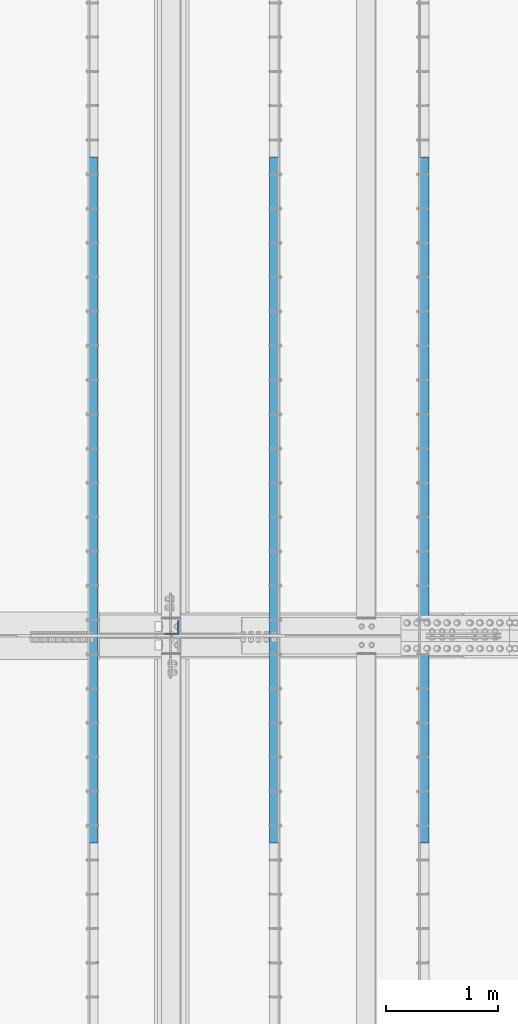
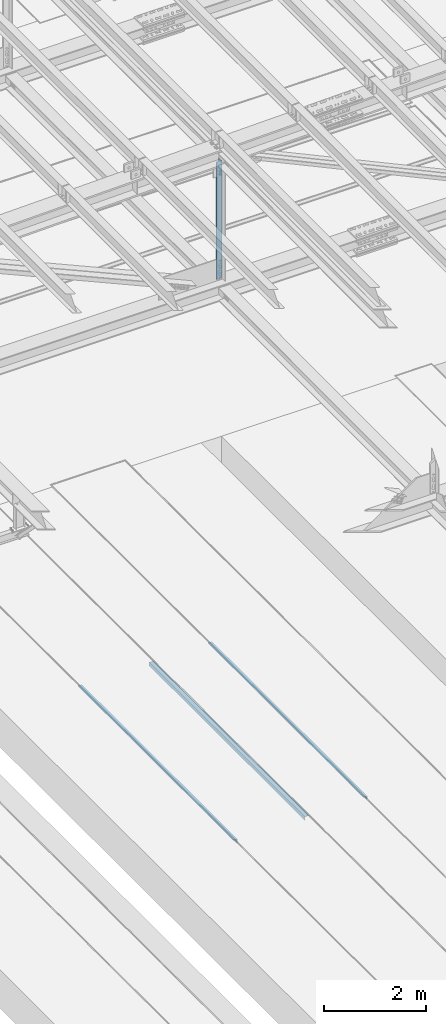
# One storey, part 1827 of 3843: 4 beams, 4 elements without a shape of their own.
"""IFC2X3 building model written with IfcOpenShell, lengths in millimetres."""

from ifc_helpers import new_model, si_unit, frame, origin_with_axes, place, context, subcontext, project, spatial, faceted_brep, material, type_object, element, aggregate, save


model = new_model("IFC2X3")

# Units and contexts
model_context = context("Model", 3, precision=1e-05, world=origin_with_axes())
body_context = subcontext(model_context, "Body", "Model", "MODEL_VIEW")
ifc_project = project(units=[si_unit("LENGTHUNIT", "METRE", prefix="MILLI"), si_unit("AREAUNIT", "SQUARE_METRE"), si_unit("VOLUMEUNIT", "CUBIC_METRE"), si_unit("MASSUNIT", "GRAM", prefix="KILO"), si_unit("TIMEUNIT", "SECOND"), si_unit("PLANEANGLEUNIT", "RADIAN"), si_unit("SOLIDANGLEUNIT", "STERADIAN"), si_unit("THERMODYNAMICTEMPERATUREUNIT", "DEGREE_CELSIUS"), si_unit("LUMINOUSINTENSITYUNIT", "LUMEN")], contexts=[model_context])

# Site, building, storey
site_placement = place(None, origin_with_axes())
site = spatial("IfcSite", under=ifc_project, at=site_placement, CompositionType="ELEMENT")
building_placement = place(site_placement, origin_with_axes())
building = spatial("IfcBuilding", under=site, at=building_placement, Name="Undefined", CompositionType="ELEMENT")
storey_placement = place(building_placement, origin_with_axes())
storey = spatial("IfcBuildingStorey", under=building, at=storey_placement, Name="Undefined", CompositionType="ELEMENT", Elevation=0.0)

# Assembly, beam
assembly_1_placement = place(storey_placement, origin_with_axes())
assembly_1 = element("IfcElementAssembly", 1, at=assembly_1_placement, inside=storey, Name="EMBED_ANGLE", AssemblyPlace="NOTDEFINED", PredefinedType="RIGID_FRAME")
ifc_material_1 = material(Name="STEEL/A36")
beam_type_1 = type_object("IfcBeamType", Name="L3-1/2X3-1/2X5/16", PredefinedType="NOTDEFINED")
beam_1_placement = place(assembly_1_placement, frame((51238.911984375, 40360.599609375, 30410.15), z_axis=(0.0, 0.0, -1.0), x_axis=(0.0, 1.0, 0.0)))
beam_1 = element("IfcBeam", 2, at=beam_1_placement, type_object=beam_type_1, material=ifc_material_1, Name="EMBED_ANGLE", ObjectType="L3-1/2X3-1/2X5/16", context=body_context, shape_type="Brep", body=[
    faceted_brep([(-3.63797880709171e-12, 44.4499999999971, -44.4500000000007), (-3.63797880709171e-12, 44.4499999999971, 44.4500000000007), (6096.0, 44.4499999999971, 44.4500000000007), (6096.0, 44.4499999999971, -44.4500000000007), (-3.63797880709171e-12, 36.5124999999971, 44.4500000000007), (6096.0, 36.5124999999971, 44.4500000000007), (-3.63797880709171e-12, 36.5124999999971, -36.5125000000007), (6096.0, 36.5124999999971, -36.5125000000007), (3.63797880709171e-12, -44.4499999999971, -36.5125000000007), (6096.0, -44.4499999999971, -36.5125000000007), (3.63797880709171e-12, -44.4499999999971, -44.4500000000007), (6096.0, -44.4499999999971, -44.4500000000007)], [[[0, 1, 2, 3]], [[1, 4, 5, 2]], [[4, 6, 7, 5]], [[6, 8, 9, 7]], [[8, 10, 11, 9]], [[10, 0, 3, 11]], [[5, 7, 9, 11, 3, 2]], [[10, 8, 6, 4, 1, 0]]]),
])
aggregate(assembly_1, [beam_1])

assembly_2_placement = place(storey_placement, origin_with_axes())
assembly_2 = element("IfcElementAssembly", 3, at=assembly_2_placement, inside=storey, Name="EMBED_ANGLE", AssemblyPlace="NOTDEFINED", PredefinedType="RIGID_FRAME")
beam_2_placement = place(assembly_2_placement, frame((49911.7620576172, 46456.599609375, 30410.15), z_axis=(0.0, 0.0, -1.0), x_axis=(0.0, -1.0, 0.0)))
beam_2 = element("IfcBeam", 4, at=beam_2_placement, type_object=beam_type_1, material=ifc_material_1, Name="EMBED_ANGLE", ObjectType="L3-1/2X3-1/2X5/16", context=body_context, shape_type="Brep", body=[
    faceted_brep([(-3.63797880709171e-12, 44.4499999999971, -44.4500000000007), (-3.63797880709171e-12, 44.4499999999971, 44.4500000000007), (6096.0, 44.4499999999971, 44.4500000000007), (6096.0, 44.4499999999971, -44.4500000000007), (-3.63797880709171e-12, 36.5124999999971, 44.4500000000007), (6096.0, 36.5124999999971, 44.4500000000007), (-3.63797880709171e-12, 36.5124999999971, -36.5125000000007), (6096.0, 36.5124999999971, -36.5125000000007), (3.63797880709171e-12, -44.4499999999971, -36.5125000000007), (6096.0, -44.4499999999971, -36.5125000000007), (3.63797880709171e-12, -44.4499999999971, -44.4500000000007), (6096.0, -44.4499999999971, -44.4500000000007)], [[[0, 1, 2, 3]], [[1, 4, 5, 2]], [[4, 6, 7, 5]], [[6, 8, 9, 7]], [[8, 10, 11, 9]], [[10, 0, 3, 11]], [[5, 7, 9, 11, 3, 2]], [[10, 8, 6, 4, 1, 0]]]),
])
aggregate(assembly_2, [beam_2])

assembly_3_placement = place(storey_placement, origin_with_axes())
assembly_3 = element("IfcElementAssembly", 5, at=assembly_3_placement, inside=storey, Name="EMBED_ANGLE", AssemblyPlace="NOTDEFINED", PredefinedType="RIGID_FRAME")
beam_3_placement = place(assembly_3_placement, frame((48298.8616210938, 40360.6001953125, 30410.15), z_axis=(0.0, 0.0, -1.0), x_axis=(0.0, 1.0, 0.0)))
beam_3 = element("IfcBeam", 6, at=beam_3_placement, type_object=beam_type_1, material=ifc_material_1, Name="EMBED_ANGLE", ObjectType="L3-1/2X3-1/2X5/16", context=body_context, shape_type="Brep", body=[
    faceted_brep([(-3.63797880709171e-12, 44.4499999999971, -44.4500000000007), (-3.63797880709171e-12, 44.4499999999971, 44.4500000000007), (6096.0, 44.4499999999971, 44.4500000000007), (6096.0, 44.4499999999971, -44.4500000000007), (-3.63797880709171e-12, 36.5124999999971, 44.4500000000007), (6096.0, 36.5124999999971, 44.4500000000007), (-3.63797880709171e-12, 36.5124999999971, -36.5125000000007), (6096.0, 36.5124999999971, -36.5125000000007), (3.63797880709171e-12, -44.4499999999971, -36.5125000000007), (6096.0, -44.4499999999971, -36.5125000000007), (3.63797880709171e-12, -44.4499999999971, -44.4500000000007), (6096.0, -44.4499999999971, -44.4500000000007)], [[[0, 1, 2, 3]], [[1, 4, 5, 2]], [[4, 6, 7, 5]], [[6, 8, 9, 7]], [[8, 10, 11, 9]], [[10, 0, 3, 11]], [[5, 7, 9, 11, 3, 2]], [[10, 8, 6, 4, 1, 0]]]),
])
aggregate(assembly_3, [beam_3])

assembly_4_placement = place(storey_placement, origin_with_axes())
assembly_4 = element("IfcElementAssembly", 7, at=assembly_4_placement, inside=storey, Name="ANGLE", AssemblyPlace="NOTDEFINED", PredefinedType="RIGID_FRAME")
ifc_material_2 = material(Name="STEEL/A572-50")
beam_type_2 = type_object("IfcBeamType", Name="L5X5X3/8", PredefinedType="NOTDEFINED")
beam_4_placement = place(assembly_4_placement, frame((48996.5999997284, 42275.125, 45536.1429226024), z_axis=(-1.0, 0.0, 0.0), x_axis=(0.0, 0.0, -1.0)))
beam_4 = element("IfcBeam", 8, at=beam_4_placement, type_object=beam_type_2, material=ifc_material_2, Name="ANGLE", ObjectType="L5X5X3/8", context=body_context, shape_type="Brep", body=[
    faceted_brep([(225.062338432319, 63.5, -63.5), (225.062338432319, 63.5, 63.5), (3027.95493763791, 63.5, 63.5), (3027.95493763791, 63.5, -63.5), (225.062338432319, 53.9749999999985, 63.5), (3027.95493763791, 53.9749999999985, 63.5), (225.062338432319, 53.9749999999985, -53.9749999999985), (3027.95493763791, 53.9749999999985, -53.9749999999985), (225.062338432319, -63.5, -53.9749999999985), (3027.95493763791, -63.5, -53.9749999999985), (225.062338432319, -63.5, -63.5), (3027.95493763791, -63.5, -63.5)], [[[0, 1, 2, 3]], [[1, 4, 5, 2]], [[4, 6, 7, 5]], [[6, 8, 9, 7]], [[8, 10, 11, 9]], [[10, 0, 3, 11]], [[5, 7, 9, 11, 3, 2]], [[10, 8, 6, 4, 1, 0]]]),
])
aggregate(assembly_4, [beam_4])

save(model, "model.ifc")
